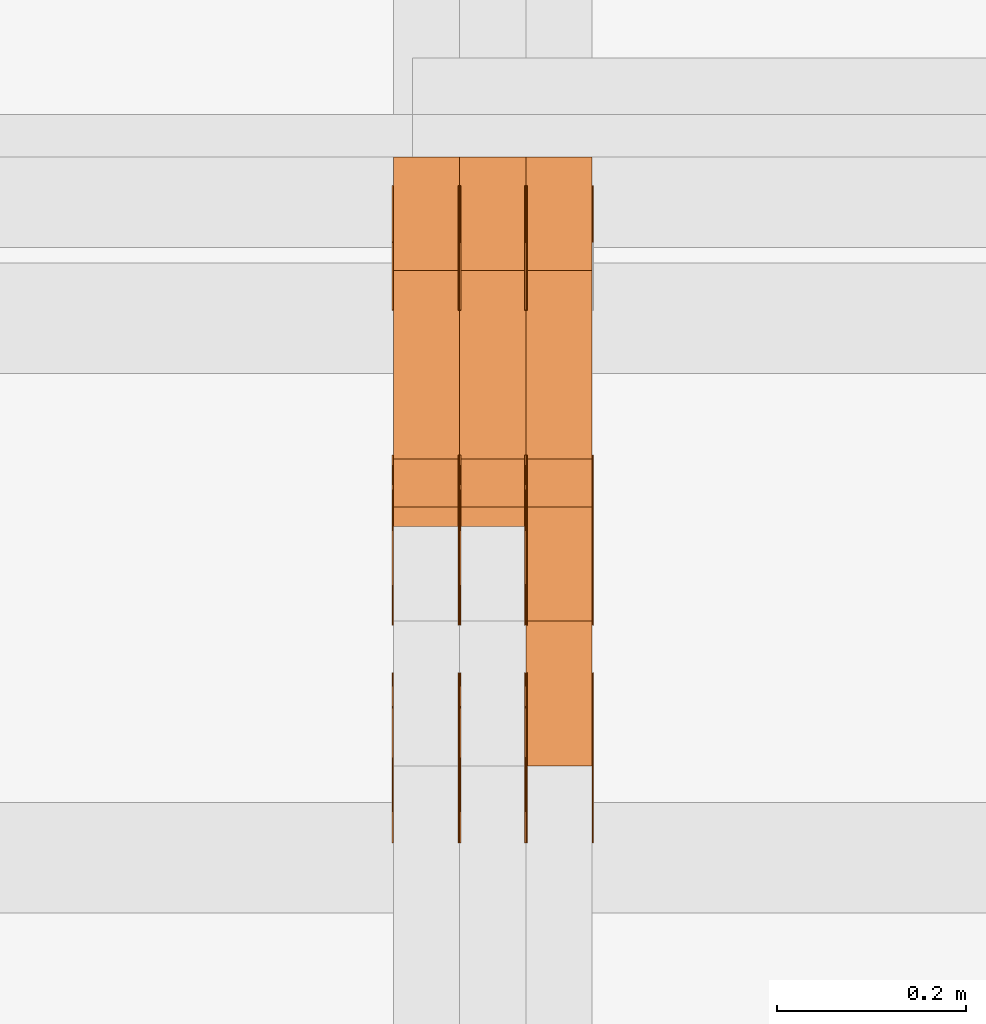
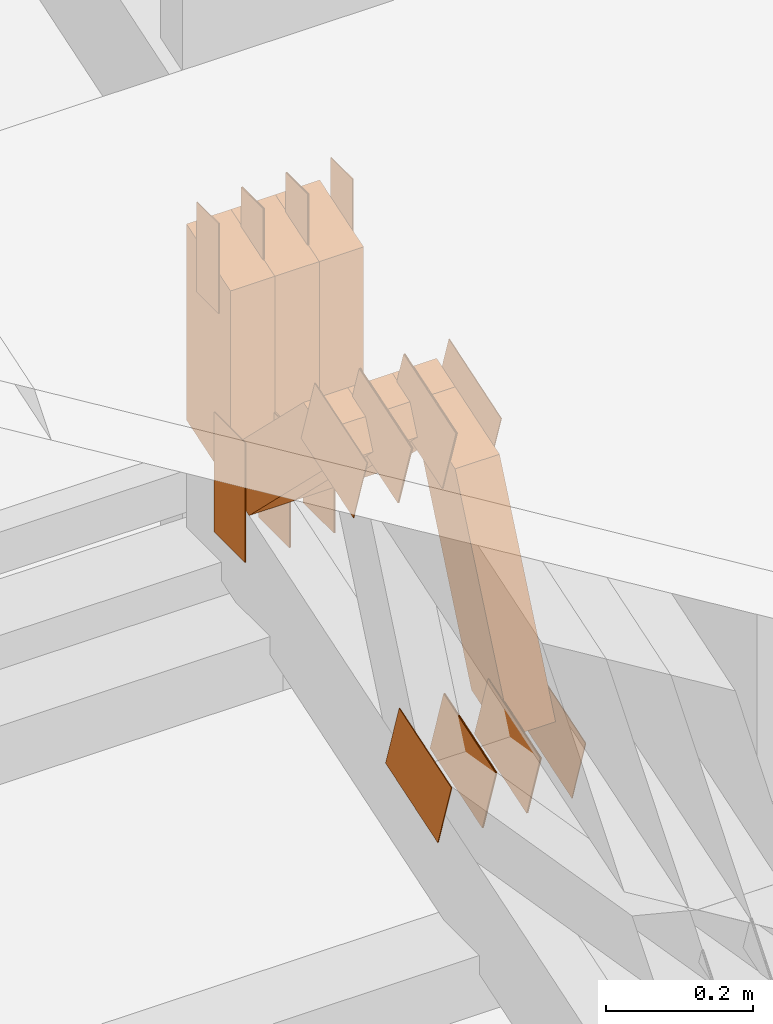
# One storey, part 284 of 385: 30 proxies.
"""IFC2X3 building model written with IfcOpenShell, lengths in millimetres."""

from ifc_helpers import new_model, entity, si_unit, converted_unit, derived_unit, direction, frame, frame_2d, origin, origin_2d_with_axis, place, context, subcontext, project, spatial, polyline, rectangle, outline, extrude, source, transform, mapped, material, type_object, type_shapes, element, save


model = new_model("IFC2X3")

# Units and contexts
model_context = context("Model", 3, precision=0.01, world=origin(), true_north=direction((6.12303176911189e-17, 1.0)))
body_context = subcontext(model_context, "Body", "Model", "MODEL_VIEW")
ifc_project = project(units=[si_unit("LENGTHUNIT", "METRE", prefix="MILLI"), si_unit("AREAUNIT", "SQUARE_METRE"), si_unit("VOLUMEUNIT", "CUBIC_METRE"), converted_unit("PLANEANGLEUNIT", "DEGREE", entity("IfcRatioMeasure", 0.0174532925199433), si_unit("PLANEANGLEUNIT", "RADIAN"), dimensions=[0, 0, 0, 0, 0, 0, 0]), si_unit("MASSUNIT", "GRAM", prefix="KILO"), derived_unit("MASSDENSITYUNIT", [(si_unit("MASSUNIT", "GRAM", prefix="KILO"), 1), (si_unit("LENGTHUNIT", "METRE"), -3)]), si_unit("TIMEUNIT", "SECOND"), si_unit("FREQUENCYUNIT", "HERTZ"), si_unit("THERMODYNAMICTEMPERATUREUNIT", "DEGREE_CELSIUS"), derived_unit("THERMALTRANSMITTANCEUNIT", [(si_unit("MASSUNIT", "GRAM", prefix="KILO"), 1), (si_unit("THERMODYNAMICTEMPERATUREUNIT", "KELVIN"), -1), (si_unit("TIMEUNIT", "SECOND"), -3)]), derived_unit("VOLUMETRICFLOWRATEUNIT", [(si_unit("LENGTHUNIT", "METRE"), 3), (si_unit("TIMEUNIT", "SECOND"), -1)]), si_unit("ELECTRICCURRENTUNIT", "AMPERE"), si_unit("ELECTRICVOLTAGEUNIT", "VOLT"), si_unit("POWERUNIT", "WATT"), si_unit("FORCEUNIT", "NEWTON", prefix="KILO"), si_unit("ILLUMINANCEUNIT", "LUX"), si_unit("LUMINOUSFLUXUNIT", "LUMEN"), si_unit("LUMINOUSINTENSITYUNIT", "CANDELA"), derived_unit("USERDEFINED", [(si_unit("MASSUNIT", "GRAM", prefix="KILO"), -1), (si_unit("LENGTHUNIT", "METRE"), -2), (si_unit("TIMEUNIT", "SECOND"), 3), (si_unit("LUMINOUSFLUXUNIT", "LUMEN"), 1)]), derived_unit("LINEARVELOCITYUNIT", [(si_unit("LENGTHUNIT", "METRE"), 1), (si_unit("TIMEUNIT", "SECOND"), -1)]), si_unit("PRESSUREUNIT", "PASCAL"), derived_unit("USERDEFINED", [(si_unit("LENGTHUNIT", "METRE"), -2), (si_unit("MASSUNIT", "GRAM", prefix="KILO"), 1), (si_unit("TIMEUNIT", "SECOND"), -2)])], contexts=[model_context])

# Site, building, storey
site_placement = place(None, origin())
site = spatial("IfcSite", under=ifc_project, at=site_placement, CompositionType="ELEMENT")
building_placement = place(site_placement, origin())
building = spatial("IfcBuilding", under=site, at=building_placement, CompositionType="ELEMENT")
storey_placement = place(building_placement, origin())
storey = spatial("IfcBuildingStorey", under=building, at=storey_placement, Name="Default", CompositionType="ELEMENT", Elevation=0.0)

# Proxies
ifc_material_1 = material(Name="IfcSurfaceStyle #484539")
building_element_proxy_type_1 = type_object("IfcBuildingElementProxyType", PredefinedType="NOTDEFINED", material=ifc_material_1)
shared_shape_1 = source(origin(), body_context, "Body", "SweptSolid", [
    extrude(rectangle(XDim=200.0, YDim=84.0, at=frame_2d((0.0, -7.105427357601e-15), x_axis=(1.0, 0.0))), frame((100.0, 42.0, 0.0), z_axis=(0.0, 0.0, 1.0), x_axis=(-1.0, 0.0, 0.0)), (0.0, 0.0, 1.0), 1.3),
])
type_shapes(building_element_proxy_type_1, [shared_shape_1])
proxy_1_placement = place(building_placement, frame((39315.0, 13702.0, 3651.4150390625), z_axis=(-1.0, 0.0, 0.0), x_axis=(0.0, 0.0, -1.0)))
element("IfcBuildingElementProxy", 1, at=proxy_1_placement, inside=storey, type_object=building_element_proxy_type_1, material=ifc_material_1, context=body_context, shape_type="MappedRepresentation", body=[
    mapped(shared_shape_1, transform((0.0, 0.0, 0.0), scale=1.0)),
])
ifc_material_2 = material(Name="IfcSurfaceStyle #484482")
building_element_proxy_type_2 = type_object("IfcBuildingElementProxyType", PredefinedType="NOTDEFINED", material=ifc_material_2)
shared_shape_2 = source(origin(), body_context, "Body", "SweptSolid", [
    extrude(rectangle(XDim=200.0, YDim=84.0, at=frame_2d((0.0, -7.105427357601e-15), x_axis=(1.0, 0.0))), frame((100.0, 42.0, 0.0), z_axis=(0.0, 0.0, 1.0), x_axis=(-1.0, 0.0, 0.0)), (0.0, 0.0, 1.0), 1.3),
])
type_shapes(building_element_proxy_type_2, [shared_shape_2])
proxy_2_placement = place(building_placement, frame((39316.3, 13702.0, 3651.4150390625), z_axis=(-1.0, 0.0, 0.0), x_axis=(0.0, 0.0, -1.0)))
element("IfcBuildingElementProxy", 2, at=proxy_2_placement, inside=storey, type_object=building_element_proxy_type_2, material=ifc_material_2, context=body_context, shape_type="MappedRepresentation", body=[
    mapped(shared_shape_2, transform((0.0, 0.0, 0.0), scale=1.0)),
])
ifc_material_3 = material(Name="IfcSurfaceStyle #484425")
building_element_proxy_type_3 = type_object("IfcBuildingElementProxyType", PredefinedType="NOTDEFINED", material=ifc_material_3)
shared_shape_3 = source(origin(), body_context, "Body", "SweptSolid", [
    extrude(rectangle(XDim=200.0, YDim=84.0, at=frame_2d((0.0, -7.105427357601e-15), x_axis=(1.0, 0.0))), frame((100.0, 42.0, 0.0), z_axis=(0.0, 0.0, 1.0), x_axis=(-1.0, 0.0, 0.0)), (0.0, 0.0, 1.0), 1.29999999999998),
])
type_shapes(building_element_proxy_type_3, [shared_shape_3])
proxy_3_placement = place(building_placement, frame((39245.0, 13702.0, 3651.4150390625), z_axis=(-1.0, 0.0, 0.0), x_axis=(0.0, 0.0, -1.0)))
element("IfcBuildingElementProxy", 3, at=proxy_3_placement, inside=storey, type_object=building_element_proxy_type_3, material=ifc_material_3, context=body_context, shape_type="MappedRepresentation", body=[
    mapped(shared_shape_3, transform((0.0, 0.0, 0.0), scale=1.0)),
])
ifc_material_4 = material(Name="IfcSurfaceStyle #484368")
building_element_proxy_type_4 = type_object("IfcBuildingElementProxyType", PredefinedType="NOTDEFINED", material=ifc_material_4)
shared_shape_4 = source(origin(), body_context, "Body", "SweptSolid", [
    extrude(rectangle(XDim=200.0, YDim=84.0, at=frame_2d((0.0, -7.105427357601e-15), x_axis=(1.0, 0.0))), frame((100.0, 42.0, 0.0), z_axis=(0.0, 0.0, 1.0), x_axis=(-1.0, 0.0, 0.0)), (0.0, 0.0, 1.0), 1.29999999999998),
])
type_shapes(building_element_proxy_type_4, [shared_shape_4])
proxy_4_placement = place(building_placement, frame((39246.3, 13702.0, 3651.4150390625), z_axis=(-1.0, 0.0, 0.0), x_axis=(0.0, 0.0, -1.0)))
element("IfcBuildingElementProxy", 4, at=proxy_4_placement, inside=storey, type_object=building_element_proxy_type_4, material=ifc_material_4, context=body_context, shape_type="MappedRepresentation", body=[
    mapped(shared_shape_4, transform((0.0, 0.0, 0.0), scale=1.0)),
])
ifc_material_5 = material(Name="IfcSurfaceStyle #484311")
building_element_proxy_type_5 = type_object("IfcBuildingElementProxyType", PredefinedType="NOTDEFINED", material=ifc_material_5)
shared_shape_5 = source(origin(), body_context, "Body", "SweptSolid", [
    extrude(rectangle(XDim=200.0, YDim=84.0, at=frame_2d((0.0, -7.105427357601e-15), x_axis=(1.0, 0.0))), frame((100.0, 42.0, 0.0), z_axis=(0.0, 0.0, 1.0), x_axis=(-1.0, 0.0, 0.0)), (0.0, 0.0, 1.0), 1.29999999999999),
])
type_shapes(building_element_proxy_type_5, [shared_shape_5])
proxy_5_placement = place(building_placement, frame((39175.0, 13702.0, 3651.4150390625), z_axis=(-1.0, 0.0, 0.0), x_axis=(0.0, 0.0, -1.0)))
element("IfcBuildingElementProxy", 5, at=proxy_5_placement, inside=storey, type_object=building_element_proxy_type_5, material=ifc_material_5, context=body_context, shape_type="MappedRepresentation", body=[
    mapped(shared_shape_5, transform((0.0, 0.0, 0.0), scale=1.0)),
])
ifc_material_6 = material(Name="IfcSurfaceStyle #484254")
building_element_proxy_type_6 = type_object("IfcBuildingElementProxyType", PredefinedType="NOTDEFINED", material=ifc_material_6)
shared_shape_6 = source(origin(), body_context, "Body", "SweptSolid", [
    extrude(outline(polyline([(-75.0003398116828, -59.9998507501386), (75.0003249421766, -59.9998507501386), (75.0003398116837, 59.9998507501387), (-75.0003249421775, 59.9998507501387), (-75.0003398116828, -59.9998507501386)])), frame((75.0003398116837, 60.0000773549637, 0.0), z_axis=(0.0, 0.0, 1.0), x_axis=(-1.0, 0.0, 0.0)), (0.0, 0.0, 1.0), 1.3),
])
type_shapes(building_element_proxy_type_6, [shared_shape_6])
proxy_6_placement = place(building_placement, frame((39386.3, 13054.73046875, 3417.8388671875), z_axis=(-1.0, 0.0, 0.0), x_axis=(0.0, 0.951056516295124, 0.309016994375039)))
element("IfcBuildingElementProxy", 6, at=proxy_6_placement, inside=storey, type_object=building_element_proxy_type_6, material=ifc_material_6, context=body_context, shape_type="MappedRepresentation", body=[
    mapped(shared_shape_6, transform((0.0, 0.0, 0.0), scale=1.0)),
])
ifc_material_7 = material(Name="IfcSurfaceStyle #484197")
building_element_proxy_type_7 = type_object("IfcBuildingElementProxyType", PredefinedType="NOTDEFINED", material=ifc_material_7)
shared_shape_7 = source(origin(), body_context, "Body", "SweptSolid", [
    extrude(outline(polyline([(-75.0003398116828, -59.9998507501386), (75.0003249421766, -59.9998507501386), (75.0003398116837, 59.9998507501387), (-75.0003249421775, 59.9998507501387), (-75.0003398116828, -59.9998507501386)])), frame((75.0003398116837, 60.0000773549637, 0.0), z_axis=(0.0, 0.0, 1.0), x_axis=(-1.0, 0.0, 0.0)), (0.0, 0.0, 1.0), 1.3),
])
type_shapes(building_element_proxy_type_7, [shared_shape_7])
proxy_7_placement = place(building_placement, frame((39315.0, 13054.73046875, 3417.8388671875), z_axis=(-1.0, 0.0, 0.0), x_axis=(0.0, 0.951056516295124, 0.309016994375039)))
element("IfcBuildingElementProxy", 7, at=proxy_7_placement, inside=storey, type_object=building_element_proxy_type_7, material=ifc_material_7, context=body_context, shape_type="MappedRepresentation", body=[
    mapped(shared_shape_7, transform((0.0, 0.0, 0.0), scale=1.0)),
])
ifc_material_8 = material(Name="IfcSurfaceStyle #484140")
building_element_proxy_type_8 = type_object("IfcBuildingElementProxyType", PredefinedType="NOTDEFINED", material=ifc_material_8)
shared_shape_8 = source(origin(), body_context, "Body", "SweptSolid", [
    extrude(outline(polyline([(-75.0003398116828, -59.9998507501386), (75.0003249421766, -59.9998507501386), (75.0003398116837, 59.9998507501387), (-75.0003249421775, 59.9998507501387), (-75.0003398116828, -59.9998507501386)])), frame((75.0003398116837, 60.0000773549637, 0.0), z_axis=(0.0, 0.0, 1.0), x_axis=(-1.0, 0.0, 0.0)), (0.0, 0.0, 1.0), 1.3),
])
type_shapes(building_element_proxy_type_8, [shared_shape_8])
proxy_8_placement = place(building_placement, frame((39316.3, 13054.73046875, 3417.8388671875), z_axis=(-1.0, 0.0, 0.0), x_axis=(0.0, 0.951056516295124, 0.309016994375039)))
element("IfcBuildingElementProxy", 8, at=proxy_8_placement, inside=storey, type_object=building_element_proxy_type_8, material=ifc_material_8, context=body_context, shape_type="MappedRepresentation", body=[
    mapped(shared_shape_8, transform((0.0, 0.0, 0.0), scale=1.0)),
])
ifc_material_9 = material(Name="IfcSurfaceStyle #484083")
building_element_proxy_type_9 = type_object("IfcBuildingElementProxyType", PredefinedType="NOTDEFINED", material=ifc_material_9)
shared_shape_9 = source(origin(), body_context, "Body", "SweptSolid", [
    extrude(outline(polyline([(-75.0003398116828, -59.9998507501386), (75.0003249421766, -59.9998507501386), (75.0003398116837, 59.9998507501387), (-75.0003249421775, 59.9998507501387), (-75.0003398116828, -59.9998507501386)])), frame((75.0003398116837, 60.0000773549637, 0.0), z_axis=(0.0, 0.0, 1.0), x_axis=(-1.0, 0.0, 0.0)), (0.0, 0.0, 1.0), 1.29999999999999),
])
type_shapes(building_element_proxy_type_9, [shared_shape_9])
proxy_9_placement = place(building_placement, frame((39245.0, 13054.73046875, 3417.8388671875), z_axis=(-1.0, 0.0, 0.0), x_axis=(0.0, 0.951056516295124, 0.309016994375039)))
element("IfcBuildingElementProxy", 9, at=proxy_9_placement, inside=storey, type_object=building_element_proxy_type_9, material=ifc_material_9, context=body_context, shape_type="MappedRepresentation", body=[
    mapped(shared_shape_9, transform((0.0, 0.0, 0.0), scale=1.0)),
])
ifc_material_10 = material(Name="IfcSurfaceStyle #484026")
building_element_proxy_type_10 = type_object("IfcBuildingElementProxyType", PredefinedType="NOTDEFINED", material=ifc_material_10)
shared_shape_10 = source(origin(), body_context, "Body", "SweptSolid", [
    extrude(outline(polyline([(-75.0003398116828, -59.9998507501386), (75.0003249421766, -59.9998507501386), (75.0003398116837, 59.9998507501387), (-75.0003249421775, 59.9998507501387), (-75.0003398116828, -59.9998507501386)])), frame((75.0003398116837, 60.0000773549637, 0.0), z_axis=(0.0, 0.0, 1.0), x_axis=(-1.0, 0.0, 0.0)), (0.0, 0.0, 1.0), 1.29999999999999),
])
type_shapes(building_element_proxy_type_10, [shared_shape_10])
proxy_10_placement = place(building_placement, frame((39246.3, 13054.73046875, 3417.8388671875), z_axis=(-1.0, 0.0, 0.0), x_axis=(0.0, 0.951056516295124, 0.309016994375039)))
element("IfcBuildingElementProxy", 10, at=proxy_10_placement, inside=storey, type_object=building_element_proxy_type_10, material=ifc_material_10, context=body_context, shape_type="MappedRepresentation", body=[
    mapped(shared_shape_10, transform((0.0, 0.0, 0.0), scale=1.0)),
])
ifc_material_11 = material(Name="IfcSurfaceStyle #483969")
building_element_proxy_type_11 = type_object("IfcBuildingElementProxyType", PredefinedType="NOTDEFINED", material=ifc_material_11)
shared_shape_11 = source(origin(), body_context, "Body", "SweptSolid", [
    extrude(outline(polyline([(-75.0003398116828, -59.9998507501386), (75.0003249421766, -59.9998507501386), (75.0003398116837, 59.9998507501387), (-75.0003249421775, 59.9998507501387), (-75.0003398116828, -59.9998507501386)])), frame((75.0003398116837, 60.0000773549637, 0.0), z_axis=(0.0, 0.0, 1.0), x_axis=(-1.0, 0.0, 0.0)), (0.0, 0.0, 1.0), 1.29999999999999),
])
type_shapes(building_element_proxy_type_11, [shared_shape_11])
proxy_11_placement = place(building_placement, frame((39175.0, 13054.73046875, 3417.8388671875), z_axis=(-1.0, 0.0, 0.0), x_axis=(0.0, 0.951056516295124, 0.309016994375039)))
element("IfcBuildingElementProxy", 11, at=proxy_11_placement, inside=storey, type_object=building_element_proxy_type_11, material=ifc_material_11, context=body_context, shape_type="MappedRepresentation", body=[
    mapped(shared_shape_11, transform((0.0, 0.0, 0.0), scale=1.0)),
])
ifc_material_12 = material(Name="IfcSurfaceStyle #476388")
building_element_proxy_type_12 = type_object("IfcBuildingElementProxyType", PredefinedType="NOTDEFINED", material=ifc_material_12)
shared_shape_12 = source(origin(), body_context, "Body", "SweptSolid", [
    extrude(outline(polyline([(-74.999875428623, -60.0000016373506), (74.9998605591059, -60.0000016373506), (74.9998754286239, 60.0000016373506), (-74.9998605591068, 60.0000016373506), (-74.999875428623, -60.0000016373506)])), frame((75.0002691827262, 60.0000190504561, 0.0), z_axis=(0.0, 0.0, 1.0), x_axis=(-1.0, 0.0, 0.0)), (0.0, 0.0, 1.0), 1.3),
])
type_shapes(building_element_proxy_type_12, [shared_shape_12])
proxy_12_placement = place(building_placement, frame((39386.3, 13285.0865109705, 3819.37496637467), z_axis=(-1.0, 0.0, 0.0), x_axis=(0.0, 0.951056516295154, 0.309016994374948)))
element("IfcBuildingElementProxy", 12, at=proxy_12_placement, inside=storey, type_object=building_element_proxy_type_12, material=ifc_material_12, context=body_context, shape_type="MappedRepresentation", body=[
    mapped(shared_shape_12, transform((0.0, 0.0, 0.0), scale=1.0)),
])
ifc_material_13 = material(Name="IfcSurfaceStyle #476331")
building_element_proxy_type_13 = type_object("IfcBuildingElementProxyType", PredefinedType="NOTDEFINED", material=ifc_material_13)
shared_shape_13 = source(origin(), body_context, "Body", "SweptSolid", [
    extrude(outline(polyline([(-74.999875428623, -60.0000016373506), (74.9998605591059, -60.0000016373506), (74.9998754286239, 60.0000016373506), (-74.9998605591068, 60.0000016373506), (-74.999875428623, -60.0000016373506)])), frame((75.0002691827262, 60.0000190504561, 0.0), z_axis=(0.0, 0.0, 1.0), x_axis=(-1.0, 0.0, 0.0)), (0.0, 0.0, 1.0), 1.3),
])
type_shapes(building_element_proxy_type_13, [shared_shape_13])
proxy_13_placement = place(building_placement, frame((39315.0, 13285.0865109705, 3819.37496637467), z_axis=(-1.0, 0.0, 0.0), x_axis=(0.0, 0.951056516295154, 0.309016994374948)))
element("IfcBuildingElementProxy", 13, at=proxy_13_placement, inside=storey, type_object=building_element_proxy_type_13, material=ifc_material_13, context=body_context, shape_type="MappedRepresentation", body=[
    mapped(shared_shape_13, transform((0.0, 0.0, 0.0), scale=1.0)),
])
ifc_material_14 = material(Name="IfcSurfaceStyle #476274")
building_element_proxy_type_14 = type_object("IfcBuildingElementProxyType", PredefinedType="NOTDEFINED", material=ifc_material_14)
shared_shape_14 = source(origin(), body_context, "Body", "SweptSolid", [
    extrude(outline(polyline([(-74.999875428623, -60.0000016373506), (74.9998605591059, -60.0000016373506), (74.9998754286239, 60.0000016373506), (-74.9998605591068, 60.0000016373506), (-74.999875428623, -60.0000016373506)])), frame((75.0002691827262, 60.0000190504561, 0.0), z_axis=(0.0, 0.0, 1.0), x_axis=(-1.0, 0.0, 0.0)), (0.0, 0.0, 1.0), 1.3),
])
type_shapes(building_element_proxy_type_14, [shared_shape_14])
proxy_14_placement = place(building_placement, frame((39316.3, 13285.0865109705, 3819.37496637467), z_axis=(-1.0, 0.0, 0.0), x_axis=(0.0, 0.951056516295154, 0.309016994374948)))
element("IfcBuildingElementProxy", 14, at=proxy_14_placement, inside=storey, type_object=building_element_proxy_type_14, material=ifc_material_14, context=body_context, shape_type="MappedRepresentation", body=[
    mapped(shared_shape_14, transform((0.0, 0.0, 0.0), scale=1.0)),
])
ifc_material_15 = material(Name="IfcSurfaceStyle #476217")
building_element_proxy_type_15 = type_object("IfcBuildingElementProxyType", PredefinedType="NOTDEFINED", material=ifc_material_15)
shared_shape_15 = source(origin(), body_context, "Body", "SweptSolid", [
    extrude(outline(polyline([(-74.999875428623, -60.0000016373506), (74.9998605591059, -60.0000016373506), (74.9998754286239, 60.0000016373506), (-74.9998605591068, 60.0000016373506), (-74.999875428623, -60.0000016373506)])), frame((75.0002691827262, 60.0000190504561, 0.0), z_axis=(0.0, 0.0, 1.0), x_axis=(-1.0, 0.0, 0.0)), (0.0, 0.0, 1.0), 1.29999999999999),
])
type_shapes(building_element_proxy_type_15, [shared_shape_15])
proxy_15_placement = place(building_placement, frame((39245.0, 13285.0865109705, 3819.37496637467), z_axis=(-1.0, 0.0, 0.0), x_axis=(0.0, 0.951056516295154, 0.309016994374948)))
element("IfcBuildingElementProxy", 15, at=proxy_15_placement, inside=storey, type_object=building_element_proxy_type_15, material=ifc_material_15, context=body_context, shape_type="MappedRepresentation", body=[
    mapped(shared_shape_15, transform((0.0, 0.0, 0.0), scale=1.0)),
])
ifc_material_16 = material(Name="IfcSurfaceStyle #476160")
building_element_proxy_type_16 = type_object("IfcBuildingElementProxyType", PredefinedType="NOTDEFINED", material=ifc_material_16)
shared_shape_16 = source(origin(), body_context, "Body", "SweptSolid", [
    extrude(outline(polyline([(-74.999875428623, -60.0000016373506), (74.9998605591059, -60.0000016373506), (74.9998754286239, 60.0000016373506), (-74.9998605591068, 60.0000016373506), (-74.999875428623, -60.0000016373506)])), frame((75.0002691827262, 60.0000190504561, 0.0), z_axis=(0.0, 0.0, 1.0), x_axis=(-1.0, 0.0, 0.0)), (0.0, 0.0, 1.0), 1.29999999999999),
])
type_shapes(building_element_proxy_type_16, [shared_shape_16])
proxy_16_placement = place(building_placement, frame((39246.3, 13285.0865109705, 3819.37496637467), z_axis=(-1.0, 0.0, 0.0), x_axis=(0.0, 0.951056516295154, 0.309016994374948)))
element("IfcBuildingElementProxy", 16, at=proxy_16_placement, inside=storey, type_object=building_element_proxy_type_16, material=ifc_material_16, context=body_context, shape_type="MappedRepresentation", body=[
    mapped(shared_shape_16, transform((0.0, 0.0, 0.0), scale=1.0)),
])
ifc_material_17 = material(Name="IfcSurfaceStyle #476103")
building_element_proxy_type_17 = type_object("IfcBuildingElementProxyType", PredefinedType="NOTDEFINED", material=ifc_material_17)
shared_shape_17 = source(origin(), body_context, "Body", "SweptSolid", [
    extrude(outline(polyline([(-74.999875428623, -60.0000016373506), (74.9998605591059, -60.0000016373506), (74.9998754286239, 60.0000016373506), (-74.9998605591068, 60.0000016373506), (-74.999875428623, -60.0000016373506)])), frame((75.0002691827262, 60.0000190504561, 0.0), z_axis=(0.0, 0.0, 1.0), x_axis=(-1.0, 0.0, 0.0)), (0.0, 0.0, 1.0), 1.29999999999999),
])
type_shapes(building_element_proxy_type_17, [shared_shape_17])
proxy_17_placement = place(building_placement, frame((39175.0, 13285.0865109705, 3819.37496637467), z_axis=(-1.0, 0.0, 0.0), x_axis=(0.0, 0.951056516295154, 0.309016994374948)))
element("IfcBuildingElementProxy", 17, at=proxy_17_placement, inside=storey, type_object=building_element_proxy_type_17, material=ifc_material_17, context=body_context, shape_type="MappedRepresentation", body=[
    mapped(shared_shape_17, transform((0.0, 0.0, 0.0), scale=1.0)),
])
ifc_material_18 = material(Name="IfcSurfaceStyle #475704")
building_element_proxy_type_18 = type_object("IfcBuildingElementProxyType", PredefinedType="NOTDEFINED", material=ifc_material_18)
shared_shape_18 = source(origin(), body_context, "Body", "SweptSolid", [
    extrude(rectangle(XDim=150.0, YDim=60.0, at=origin_2d_with_axis()), frame((75.0000705696166, 30.0, 0.0), z_axis=(0.0, 0.0, 1.0), x_axis=(-1.0, 0.0, 0.0)), (0.0, 0.0, 1.0), 1.3),
])
type_shapes(building_element_proxy_type_18, [shared_shape_18])
proxy_18_placement = place(building_placement, frame((39386.3, 13750.0, 3972.59919166337), z_axis=(-1.0, 0.0, 0.0), x_axis=(0.0, 0.0, -1.0)))
element("IfcBuildingElementProxy", 18, at=proxy_18_placement, inside=storey, type_object=building_element_proxy_type_18, material=ifc_material_18, context=body_context, shape_type="MappedRepresentation", body=[
    mapped(shared_shape_18, transform((0.0, 0.0, 0.0), scale=1.0)),
])
ifc_material_19 = material(Name="IfcSurfaceStyle #475647")
building_element_proxy_type_19 = type_object("IfcBuildingElementProxyType", PredefinedType="NOTDEFINED", material=ifc_material_19)
shared_shape_19 = source(origin(), body_context, "Body", "SweptSolid", [
    extrude(rectangle(XDim=150.0, YDim=60.0, at=origin_2d_with_axis()), frame((75.0000705696166, 30.0, 0.0), z_axis=(0.0, 0.0, 1.0), x_axis=(-1.0, 0.0, 0.0)), (0.0, 0.0, 1.0), 1.3),
])
type_shapes(building_element_proxy_type_19, [shared_shape_19])
proxy_19_placement = place(building_placement, frame((39315.0, 13750.0, 3972.59919166337), z_axis=(-1.0, 0.0, 0.0), x_axis=(0.0, 0.0, -1.0)))
element("IfcBuildingElementProxy", 19, at=proxy_19_placement, inside=storey, type_object=building_element_proxy_type_19, material=ifc_material_19, context=body_context, shape_type="MappedRepresentation", body=[
    mapped(shared_shape_19, transform((0.0, 0.0, 0.0), scale=1.0)),
])
ifc_material_20 = material(Name="IfcSurfaceStyle #475590")
building_element_proxy_type_20 = type_object("IfcBuildingElementProxyType", PredefinedType="NOTDEFINED", material=ifc_material_20)
shared_shape_20 = source(origin(), body_context, "Body", "SweptSolid", [
    extrude(rectangle(XDim=150.0, YDim=60.0, at=origin_2d_with_axis()), frame((75.0000705696166, 30.0, 0.0), z_axis=(0.0, 0.0, 1.0), x_axis=(-1.0, 0.0, 0.0)), (0.0, 0.0, 1.0), 1.3),
])
type_shapes(building_element_proxy_type_20, [shared_shape_20])
proxy_20_placement = place(building_placement, frame((39316.3, 13750.0, 3972.59919166337), z_axis=(-1.0, 0.0, 0.0), x_axis=(0.0, 0.0, -1.0)))
element("IfcBuildingElementProxy", 20, at=proxy_20_placement, inside=storey, type_object=building_element_proxy_type_20, material=ifc_material_20, context=body_context, shape_type="MappedRepresentation", body=[
    mapped(shared_shape_20, transform((0.0, 0.0, 0.0), scale=1.0)),
])
ifc_material_21 = material(Name="IfcSurfaceStyle #475533")
building_element_proxy_type_21 = type_object("IfcBuildingElementProxyType", PredefinedType="NOTDEFINED", material=ifc_material_21)
shared_shape_21 = source(origin(), body_context, "Body", "SweptSolid", [
    extrude(rectangle(XDim=150.0, YDim=60.0, at=origin_2d_with_axis()), frame((75.0000705696166, 30.0, 0.0), z_axis=(0.0, 0.0, 1.0), x_axis=(-1.0, 0.0, 0.0)), (0.0, 0.0, 1.0), 1.29999999999999),
])
type_shapes(building_element_proxy_type_21, [shared_shape_21])
proxy_21_placement = place(building_placement, frame((39245.0, 13750.0, 3972.59919166337), z_axis=(-1.0, 0.0, 0.0), x_axis=(0.0, 0.0, -1.0)))
element("IfcBuildingElementProxy", 21, at=proxy_21_placement, inside=storey, type_object=building_element_proxy_type_21, material=ifc_material_21, context=body_context, shape_type="MappedRepresentation", body=[
    mapped(shared_shape_21, transform((0.0, 0.0, 0.0), scale=1.0)),
])
ifc_material_22 = material(Name="IfcSurfaceStyle #475476")
building_element_proxy_type_22 = type_object("IfcBuildingElementProxyType", PredefinedType="NOTDEFINED", material=ifc_material_22)
shared_shape_22 = source(origin(), body_context, "Body", "SweptSolid", [
    extrude(rectangle(XDim=150.0, YDim=60.0, at=origin_2d_with_axis()), frame((75.0000705696166, 30.0, 0.0), z_axis=(0.0, 0.0, 1.0), x_axis=(-1.0, 0.0, 0.0)), (0.0, 0.0, 1.0), 1.29999999999999),
])
type_shapes(building_element_proxy_type_22, [shared_shape_22])
proxy_22_placement = place(building_placement, frame((39246.3, 13750.0, 3972.59919166337), z_axis=(-1.0, 0.0, 0.0), x_axis=(0.0, 0.0, -1.0)))
element("IfcBuildingElementProxy", 22, at=proxy_22_placement, inside=storey, type_object=building_element_proxy_type_22, material=ifc_material_22, context=body_context, shape_type="MappedRepresentation", body=[
    mapped(shared_shape_22, transform((0.0, 0.0, 0.0), scale=1.0)),
])
ifc_material_23 = material(Name="IfcSurfaceStyle #475419")
building_element_proxy_type_23 = type_object("IfcBuildingElementProxyType", PredefinedType="NOTDEFINED", material=ifc_material_23)
shared_shape_23 = source(origin(), body_context, "Body", "SweptSolid", [
    extrude(rectangle(XDim=150.0, YDim=60.0, at=origin_2d_with_axis()), frame((75.0000705696166, 30.0, 0.0), z_axis=(0.0, 0.0, 1.0), x_axis=(-1.0, 0.0, 0.0)), (0.0, 0.0, 1.0), 1.29999999999999),
])
type_shapes(building_element_proxy_type_23, [shared_shape_23])
proxy_23_placement = place(building_placement, frame((39175.0, 13750.0, 3972.59919166337), z_axis=(-1.0, 0.0, 0.0), x_axis=(0.0, 0.0, -1.0)))
element("IfcBuildingElementProxy", 23, at=proxy_23_placement, inside=storey, type_object=building_element_proxy_type_23, material=ifc_material_23, context=body_context, shape_type="MappedRepresentation", body=[
    mapped(shared_shape_23, transform((0.0, 0.0, 0.0), scale=1.0)),
])
ifc_material_24 = material(Name="IfcSurfaceStyle #466218")
building_element_proxy_type_24 = type_object("IfcBuildingElementProxyType", Name="T1-W49 466216", PredefinedType="NOTDEFINED", material=ifc_material_24)
shared_shape_24 = source(origin(), body_context, "Body", "SweptSolid", [
    extrude(outline(polyline([(-155.175867306415, -47.4997478409253), (152.310664695054, -47.4997478409253), (170.496756790954, -6.14570120142345e-05), (145.70957993751, 47.4998092979374), (-133.37808995724, 47.4998092979373), (-179.963044159863, -6.14570120298391e-05), (-155.175867306415, -47.4997478409253)])), frame((170.496756790954, 47.5001152140455, 0.0), z_axis=(0.0, 0.0, 1.0), x_axis=(-1.0, 0.0, 0.0)), (0.0, 0.0, 1.0), 70.0),
])
type_shapes(building_element_proxy_type_24, [shared_shape_24])
proxy_24_placement = place(building_placement, frame((39385.0, 13443.048524104, 3830.71841973934), z_axis=(-1.0, 0.0, 0.0), x_axis=(0.0, 0.713950095632063, -0.700196587357413)))
element("IfcBuildingElementProxy", 24, at=proxy_24_placement, inside=storey, type_object=building_element_proxy_type_24, material=ifc_material_24, Name="T1-W49", context=body_context, shape_type="MappedRepresentation", body=[
    mapped(shared_shape_24, transform((0.0, 0.0, 0.0), scale=1.0)),
])
ifc_material_25 = material(Name="IfcSurfaceStyle #466143")
building_element_proxy_type_25 = type_object("IfcBuildingElementProxyType", Name="T1-W49 466141", PredefinedType="NOTDEFINED", material=ifc_material_25)
shared_shape_25 = source(origin(), body_context, "Body", "SweptSolid", [
    extrude(outline(polyline([(-155.175867306415, -47.4997478409253), (152.310664695054, -47.4997478409253), (170.496756790954, -6.14570120142345e-05), (145.70957993751, 47.4998092979374), (-133.37808995724, 47.4998092979373), (-179.963044159863, -6.14570120298391e-05), (-155.175867306415, -47.4997478409253)])), frame((170.496756790954, 47.5001152140455, 0.0), z_axis=(0.0, 0.0, 1.0), x_axis=(-1.0, 0.0, 0.0)), (0.0, 0.0, 1.0), 70.0),
])
type_shapes(building_element_proxy_type_25, [shared_shape_25])
proxy_25_placement = place(building_placement, frame((39315.0, 13443.048524104, 3830.71841973934), z_axis=(-1.0, 0.0, 0.0), x_axis=(0.0, 0.713950095632063, -0.700196587357413)))
element("IfcBuildingElementProxy", 25, at=proxy_25_placement, inside=storey, type_object=building_element_proxy_type_25, material=ifc_material_25, Name="T1-W49", context=body_context, shape_type="MappedRepresentation", body=[
    mapped(shared_shape_25, transform((0.0, 0.0, 0.0), scale=1.0)),
])
ifc_material_26 = material(Name="IfcSurfaceStyle #466068")
building_element_proxy_type_26 = type_object("IfcBuildingElementProxyType", Name="T1-W49 466066", PredefinedType="NOTDEFINED", material=ifc_material_26)
shared_shape_26 = source(origin(), body_context, "Body", "SweptSolid", [
    extrude(outline(polyline([(-155.175867306415, -47.4997478409253), (152.310664695054, -47.4997478409253), (170.496756790954, -6.14570120142345e-05), (145.70957993751, 47.4998092979374), (-133.37808995724, 47.4998092979373), (-179.963044159863, -6.14570120298391e-05), (-155.175867306415, -47.4997478409253)])), frame((170.496756790954, 47.5001152140455, 0.0), z_axis=(0.0, 0.0, 1.0), x_axis=(-1.0, 0.0, 0.0)), (0.0, 0.0, 1.0), 70.0),
])
type_shapes(building_element_proxy_type_26, [shared_shape_26])
proxy_26_placement = place(building_placement, frame((39245.0, 13443.048524104, 3830.71841973934), z_axis=(-1.0, 0.0, 0.0), x_axis=(0.0, 0.713950095632063, -0.700196587357413)))
element("IfcBuildingElementProxy", 26, at=proxy_26_placement, inside=storey, type_object=building_element_proxy_type_26, material=ifc_material_26, Name="T1-W49", context=body_context, shape_type="MappedRepresentation", body=[
    mapped(shared_shape_26, transform((0.0, 0.0, 0.0), scale=1.0)),
])
ifc_material_27 = material(Name="IfcSurfaceStyle #465768")
building_element_proxy_type_27 = type_object("IfcBuildingElementProxyType", Name="T1-W1 465766", PredefinedType="NOTDEFINED", material=ifc_material_27)
shared_shape_27 = source(origin(), body_context, "Body", "SweptSolid", [
    extrude(outline(polyline([(-182.839782714844, -60.0), (143.849426269531, -60.0), (182.839660644531, 60.0), (-143.849304199219, 60.0), (-182.839782714844, -60.0)])), frame((182.839674685549, 60.0, 0.0), z_axis=(0.0, 0.0, 1.0), x_axis=(-1.0, 0.0, 0.0)), (0.0, 0.0, 1.0), 70.0),
])
type_shapes(building_element_proxy_type_27, [shared_shape_27])
proxy_27_placement = place(building_placement, frame((39385.0, 13660.0, 3551.41502502148), z_axis=(-1.0, 0.0, 0.0), x_axis=(0.0, 0.0, 1.0)))
element("IfcBuildingElementProxy", 27, at=proxy_27_placement, inside=storey, type_object=building_element_proxy_type_27, material=ifc_material_27, Name="T1-W1", context=body_context, shape_type="MappedRepresentation", body=[
    mapped(shared_shape_27, transform((0.0, 0.0, 0.0), scale=1.0)),
])
ifc_material_28 = material(Name="IfcSurfaceStyle #465711")
building_element_proxy_type_28 = type_object("IfcBuildingElementProxyType", Name="T1-W1 465709", PredefinedType="NOTDEFINED", material=ifc_material_28)
shared_shape_28 = source(origin(), body_context, "Body", "SweptSolid", [
    extrude(outline(polyline([(-182.839782714844, -60.0), (143.849426269531, -60.0), (182.839660644531, 60.0), (-143.849304199219, 60.0), (-182.839782714844, -60.0)])), frame((182.839674685549, 60.0, 0.0), z_axis=(0.0, 0.0, 1.0), x_axis=(-1.0, 0.0, 0.0)), (0.0, 0.0, 1.0), 70.0),
])
type_shapes(building_element_proxy_type_28, [shared_shape_28])
proxy_28_placement = place(building_placement, frame((39315.0, 13660.0, 3551.41502502148), z_axis=(-1.0, 0.0, 0.0), x_axis=(0.0, 0.0, 1.0)))
element("IfcBuildingElementProxy", 28, at=proxy_28_placement, inside=storey, type_object=building_element_proxy_type_28, material=ifc_material_28, Name="T1-W1", context=body_context, shape_type="MappedRepresentation", body=[
    mapped(shared_shape_28, transform((0.0, 0.0, 0.0), scale=1.0)),
])
ifc_material_29 = material(Name="IfcSurfaceStyle #465654")
building_element_proxy_type_29 = type_object("IfcBuildingElementProxyType", Name="T1-W1 465652", PredefinedType="NOTDEFINED", material=ifc_material_29)
shared_shape_29 = source(origin(), body_context, "Body", "SweptSolid", [
    extrude(outline(polyline([(-182.839782714844, -60.0), (143.849426269531, -60.0), (182.839660644531, 60.0), (-143.849304199219, 60.0), (-182.839782714844, -60.0)])), frame((182.839674685549, 60.0, 0.0), z_axis=(0.0, 0.0, 1.0), x_axis=(-1.0, 0.0, 0.0)), (0.0, 0.0, 1.0), 70.0),
])
type_shapes(building_element_proxy_type_29, [shared_shape_29])
proxy_29_placement = place(building_placement, frame((39245.0, 13660.0, 3551.41502502148), z_axis=(-1.0, 0.0, 0.0), x_axis=(0.0, 0.0, 1.0)))
element("IfcBuildingElementProxy", 29, at=proxy_29_placement, inside=storey, type_object=building_element_proxy_type_29, material=ifc_material_29, Name="T1-W1", context=body_context, shape_type="MappedRepresentation", body=[
    mapped(shared_shape_29, transform((0.0, 0.0, 0.0), scale=1.0)),
])
ifc_material_30 = material(Name="IfcSurfaceStyle #465228")
building_element_proxy_type_30 = type_object("IfcBuildingElementProxyType", Name="T1-W42 465226", PredefinedType="NOTDEFINED", material=ifc_material_30)
shared_shape_30 = source(origin(), body_context, "Body", "SweptSolid", [
    extrude(outline(polyline([(-284.837590197601, -47.4997543607933), (129.95880168156, -47.4997543607933), (171.972324990451, 0.000162623346093338), (183.717007105413, 47.4996730491203), (-200.810543579822, 47.4996730491203), (-284.837590197601, -47.4997543607933)])), frame((183.717155718752, 47.4999821655365, 0.0), z_axis=(0.0, 0.0, 1.0), x_axis=(-1.0, 0.0, 0.0)), (0.0, 0.0, 1.0), 70.0),
])
type_shapes(building_element_proxy_type_30, [shared_shape_30])
proxy_30_placement = place(building_placement, frame((39385.0, 13135.8834463264, 3404.958483022), z_axis=(-1.0, 0.0, 0.0), x_axis=(0.0, 0.398630596470292, 0.917111578575769)))
element("IfcBuildingElementProxy", 30, at=proxy_30_placement, inside=storey, type_object=building_element_proxy_type_30, material=ifc_material_30, Name="T1-W42", context=body_context, shape_type="MappedRepresentation", body=[
    mapped(shared_shape_30, transform((0.0, 0.0, 0.0), scale=1.0)),
])

save(model, "model.ifc")
